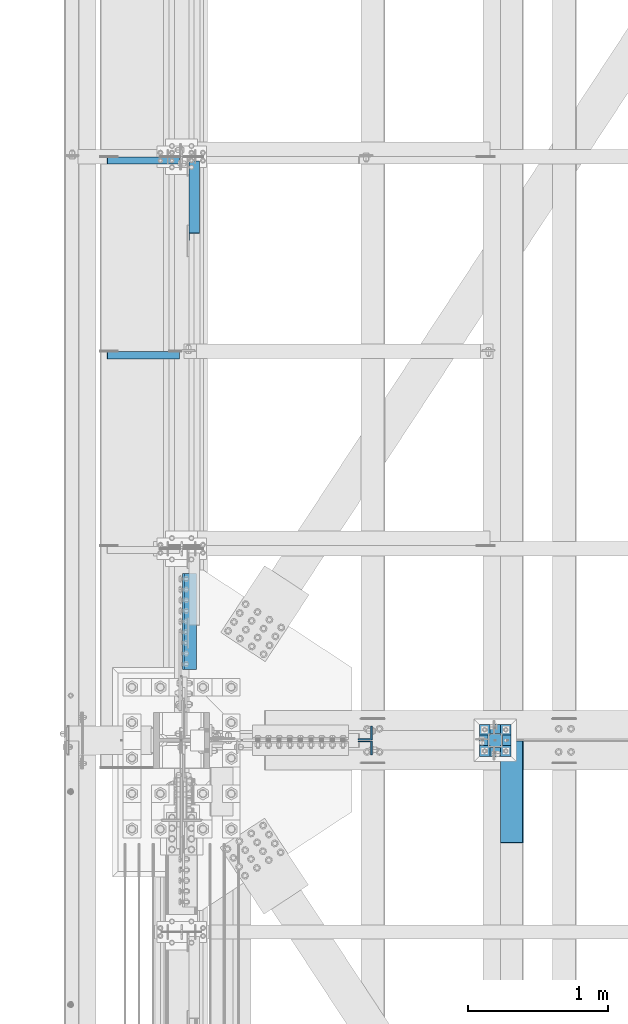
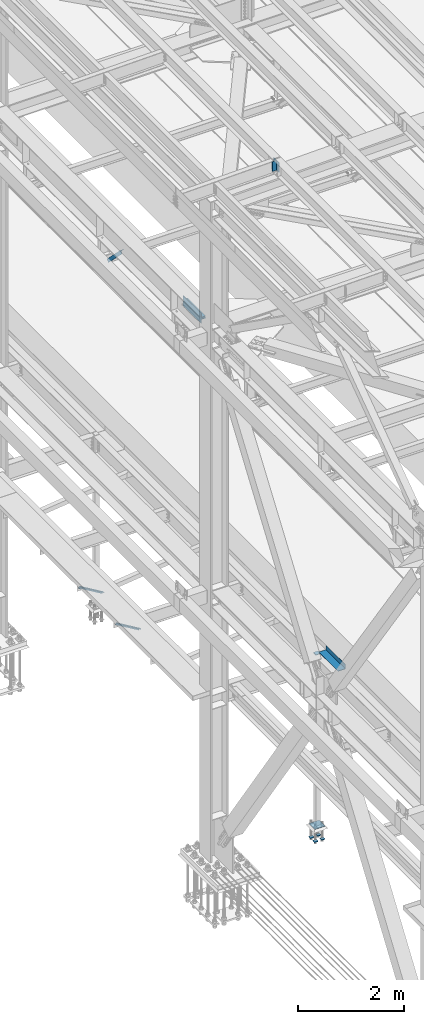
# One storey, part 2218 of 3843: 9 beams, 5 members, 8 elements without a shape of their own.
"""IFC2X3 building model written with IfcOpenShell, lengths in millimetres."""

from ifc_helpers import new_model, si_unit, frame, origin_with_axes, place, context, subcontext, project, spatial, faceted_brep, material, type_object, element, aggregate, save


model = new_model("IFC2X3")

# Units and contexts
model_context = context("Model", 3, precision=1e-05, world=origin_with_axes())
body_context = subcontext(model_context, "Body", "Model", "MODEL_VIEW")
ifc_project = project(units=[si_unit("LENGTHUNIT", "METRE", prefix="MILLI"), si_unit("AREAUNIT", "SQUARE_METRE"), si_unit("VOLUMEUNIT", "CUBIC_METRE"), si_unit("MASSUNIT", "GRAM", prefix="KILO"), si_unit("TIMEUNIT", "SECOND"), si_unit("PLANEANGLEUNIT", "RADIAN"), si_unit("SOLIDANGLEUNIT", "STERADIAN"), si_unit("THERMODYNAMICTEMPERATUREUNIT", "DEGREE_CELSIUS"), si_unit("LUMINOUSINTENSITYUNIT", "LUMEN")], contexts=[model_context])

# Site, building, storey
site_placement = place(None, origin_with_axes())
site = spatial("IfcSite", under=ifc_project, at=site_placement, CompositionType="ELEMENT")
building_placement = place(site_placement, origin_with_axes())
building = spatial("IfcBuilding", under=site, at=building_placement, Name="Undefined", CompositionType="ELEMENT")
storey_placement = place(building_placement, origin_with_axes())
storey = spatial("IfcBuildingStorey", under=building, at=storey_placement, Name="Undefined", CompositionType="ELEMENT", Elevation=0.0)

# Assembly, beam
assembly_1_placement = place(storey_placement, origin_with_axes())
assembly_1 = element("IfcElementAssembly", 1, at=assembly_1_placement, inside=storey, Name="BEAM", AssemblyPlace="NOTDEFINED", PredefinedType="RIGID_FRAME")
ifc_material_1 = material(Name="STEEL/A36")
beam_type_1 = type_object("IfcBeamType", PredefinedType="NOTDEFINED")
beam_1_placement = place(assembly_1_placement, frame((38858.825, 58547.0, 34039.175), z_axis=(0.0, -1.0, 0.0), x_axis=(1.0, 0.0, 0.0)))
beam_1 = element("IfcBeam", 2, at=beam_1_placement, type_object=beam_type_1, material=ifc_material_1, Name="BENT_PLATE", context=body_context, shape_type="Brep", body=[
    faceted_brep([(161.925005912773, 7.27595761418343e-12, 365.125000000029), (158.749999999993, 3.17500000000291, 361.950000000041), (0.0, 3.17500000000291, 361.950000000041), (0.0, 0.0, 365.125), (161.924999999988, 98.4249999999956, 365.125), (158.749999999993, 98.4249999999956, 361.950000000041), (165.099999999999, -3.17500000000291, -365.125), (0.0, -3.17500000000291, -365.125), (0.0, 3.17500000000291, -365.125), (158.749999999993, 3.17500000000291, -365.125), (158.749999999993, 98.4249999999956, -365.125), (165.099999999999, 98.4249999999956, -365.125), (165.099999999999, -3.17500000000291, 365.125), (165.099999999999, 98.4249999999956, 365.125), (0.0, -3.17500000000291, 365.125)], [[[0, 1, 2, 3]], [[4, 5, 1, 0]], [[6, 7, 8, 9, 10, 11]], [[12, 6, 11, 13]], [[14, 7, 6, 12]], [[8, 7, 14, 3, 2]], [[9, 8, 2, 1]], [[10, 9, 1, 5]], [[13, 11, 10, 5, 4]], [[14, 12, 13, 4, 0, 3]]]),
])
aggregate(assembly_1, [beam_1])

# Assembly, member
assembly_2_placement = place(storey_placement, origin_with_axes())
assembly_2 = element("IfcElementAssembly", 3, at=assembly_2_placement, inside=storey, Name="ANGLE", AssemblyPlace="NOTDEFINED", PredefinedType="RIGID_FRAME")
ifc_material_2 = material(Name="STEEL/A572-50")
member_type_1 = type_object("IfcMemberType", Name="L2X2X1/4", PredefinedType="NOTDEFINED")
member_1_placement = place(assembly_2_placement, frame((36032.7062298839, 63064.9257820001, 34001.5027629153), z_axis=(0.0, -1.0, 0.0), x_axis=(0.858158898344811, 0.0, -0.513384169206278)))
member_1 = element("IfcMember", 4, at=member_1_placement, type_object=member_type_1, material=ifc_material_2, Name="ANGLE", ObjectType="L2X2X1/4", context=body_context, shape_type="Brep", body=[
    faceted_brep([(0.0, 25.4000000000015, -25.4000000000015), (0.0, 25.4000000000015, 25.4000000000015), (598.473132324763, 25.3999999988228, 25.3999999999942), (598.473132324763, 25.3999999988228, -25.3999999999942), (0.0, 19.0500000000029, 25.4000000000015), (598.473132324745, 19.0499999988242, 25.3999999999942), (0.0, 19.0500000000029, -19.0499999999993), (598.473132324745, 19.0499999988242, -19.0500000000029), (0.0, -25.4000000000015, -19.0499999999993), (598.473132324661, -25.4000000011511, -19.0500000000029), (0.0, -25.4000000000015, -25.4000000000015), (598.473132324661, -25.4000000011511, -25.3999999999942)], [[[0, 1, 2, 3]], [[1, 4, 5, 2]], [[4, 6, 7, 5]], [[6, 8, 9, 7]], [[8, 10, 11, 9]], [[10, 0, 3, 11]], [[5, 7, 9, 11, 3, 2]], [[10, 8, 6, 4, 1, 0]]]),
])
aggregate(assembly_2, [member_1])

assembly_3_placement = place(storey_placement, origin_with_axes())
assembly_3 = element("IfcElementAssembly", 5, at=assembly_3_placement, inside=storey, Name="ANGLE", AssemblyPlace="NOTDEFINED", PredefinedType="RIGID_FRAME")
member_2_placement = place(assembly_3_placement, frame((36032.7062481198, 61672.1921880001, 34001.5027629153), z_axis=(0.0, -1.0, 0.0), x_axis=(0.858158898344811, 0.0, -0.513384169206278)))
member_2 = element("IfcMember", 6, at=member_2_placement, type_object=member_type_1, material=ifc_material_2, Name="ANGLE", ObjectType="L2X2X1/4", context=body_context, shape_type="Brep", body=[
    faceted_brep([(0.0, 25.4000000000015, -25.4000000000015), (0.0, 25.4000000000015, 25.4000000000015), (598.473132324763, 25.3999999988228, 25.3999999999942), (598.473132324763, 25.3999999988228, -25.3999999999942), (0.0, 19.0500000000029, 25.4000000000015), (598.473132324745, 19.0499999988242, 25.3999999999942), (0.0, 19.0500000000029, -19.0499999999993), (598.473132324745, 19.0499999988242, -19.0500000000029), (0.0, -25.4000000000015, -19.0499999999993), (598.473132324661, -25.4000000011511, -19.0500000000029), (0.0, -25.4000000000015, -25.4000000000015), (598.473132324661, -25.4000000011511, -25.3999999999942)], [[[0, 1, 2, 3]], [[1, 4, 5, 2]], [[4, 6, 7, 5]], [[6, 8, 9, 7]], [[8, 10, 11, 9]], [[10, 0, 3, 11]], [[5, 7, 9, 11, 3, 2]], [[10, 8, 6, 4, 1, 0]]]),
])
aggregate(assembly_3, [member_2])

# Assembly, beams
assembly_4_placement = place(storey_placement, origin_with_axes())
assembly_4 = element("IfcElementAssembly", 7, at=assembly_4_placement, inside=storey, Name="PLATE", AssemblyPlace="NOTDEFINED", PredefinedType="RIGID_FRAME")
beam_type_2 = type_object("IfcBeamType", Name="L4X4X1/2", PredefinedType="NOTDEFINED")
beam_2_placement = place(assembly_4_placement, frame((36633.1499999978, 60109.1, 42297.3500007635), z_axis=(1.0, 0.0, 0.0), x_axis=(0.0, -1.0, 0.0)))
beam_2 = element("IfcBeam", 8, at=beam_2_placement, type_object=beam_type_2, material=ifc_material_2, Name="ANGLE", ObjectType="L4X4X1/2", context=body_context, shape_type="Brep", body=[
    faceted_brep([(0.0, 50.8000000000029, -50.8000000000029), (0.0, 50.8000000000029, 50.8000000000029), (685.800000000003, 50.8000000000029, 50.8000000000029), (685.800000000003, 50.8000000000029, -50.8000000000029), (0.0, 38.0999999999985, 50.8000000000029), (685.800000000003, 38.0999999999985, 50.8000000000029), (0.0, 38.0999999999985, -38.0999999999985), (685.800000000003, 38.0999999999985, -38.1000000000058), (0.0, -50.8000000000029, -38.1000000000058), (685.800000000003, -50.8000000000029, -38.1000000000058), (0.0, -50.8000000000029, -50.8000000000029), (685.800000000003, -50.8000000000029, -50.8000000000029)], [[[0, 1, 2, 3]], [[1, 4, 5, 2]], [[4, 6, 7, 5]], [[6, 8, 9, 7]], [[8, 10, 11, 9]], [[10, 0, 3, 11]], [[5, 7, 9, 11, 3, 2]], [[10, 8, 6, 4, 1, 0]]]),
])
beam_3_placement = place(assembly_4_placement, frame((36633.1499999978, 59423.3, 42167.1750000005), z_axis=(1.0, 0.0, 0.0), x_axis=(0.0, 1.0, 0.0)))
beam_3 = element("IfcBeam", 9, at=beam_3_placement, type_object=beam_type_2, material=ifc_material_2, Name="ANGLE", ObjectType="L4X4X1/2", context=body_context, shape_type="Brep", body=[
    faceted_brep([(0.0, 50.8000000000029, -50.8000000000029), (0.0, 50.8000000000029, 50.8000000000029), (685.800000000003, 50.8000000000029, 50.8000000000029), (685.800000000003, 50.8000000000029, -50.8000000000029), (0.0, 38.0999999999985, 50.8000000000029), (685.800000000003, 38.0999999999985, 50.8000000000029), (0.0, 38.0999999999985, -38.0999999999985), (685.800000000003, 38.0999999999985, -38.1000000000058), (0.0, -50.8000000000029, -38.1000000000058), (685.800000000003, -50.8000000000029, -38.1000000000058), (0.0, -50.8000000000029, -50.8000000000029), (685.800000000003, -50.8000000000029, -50.8000000000029)], [[[0, 1, 2, 3]], [[1, 4, 5, 2]], [[4, 6, 7, 5]], [[6, 8, 9, 7]], [[8, 10, 11, 9]], [[10, 0, 3, 11]], [[5, 7, 9, 11, 3, 2]], [[10, 8, 6, 4, 1, 0]]]),
])
aggregate(assembly_4, [beam_2, beam_3])

# Assembly, members
assembly_5_placement = place(storey_placement, origin_with_axes())
assembly_5 = element("IfcElementAssembly", 10, at=assembly_5_placement, inside=storey, Name="BEAM", AssemblyPlace="NOTDEFINED", PredefinedType="RIGID_FRAME")
member_type_2 = type_object("IfcMemberType", Name="L4X4X3/8", PredefinedType="NOTDEFINED")
member_3_placement = place(assembly_5_placement, frame((37892.6968641658, 58969.2749999523, 45499.0421537386), z_axis=(0.0, 1.0, 0.0), x_axis=(-0.0211520980073474, 0.0, 0.999776269347241)))
member_3 = element("IfcMember", 11, at=member_3_placement, type_object=member_type_2, material=ifc_material_2, Name="ANGLE", ObjectType="L4X4X3/8", context=body_context, shape_type="Brep", body=[
    faceted_brep([(0.0, 50.8000000000029, -50.8000000000029), (0.0, 50.8000000000029, 50.8000000000029), (228.599999994367, 50.7999999996973, 50.8000000000029), (228.599999994367, 50.7999999996973, -50.8000000000029), (0.0, 41.2750000000015, 50.8000000000029), (228.599999994345, 41.2749999997031, 50.8000000000029), (0.0, 41.2749999999942, -41.2750000000015), (228.599999994345, 41.2749999997031, -41.2750000000015), (0.0, -50.8000000000029, -41.2750000000015), (228.599999994258, -50.8000000001412, -41.2750000000015), (0.0, -50.8000000000029, -50.8000000000029), (228.599999994258, -50.8000000001412, -50.8000000000029)], [[[0, 1, 2, 3]], [[1, 4, 5, 2]], [[4, 6, 7, 5]], [[6, 8, 9, 7]], [[8, 10, 11, 9]], [[10, 0, 3, 11]], [[5, 7, 9, 11, 3, 2]], [[10, 8, 6, 4, 1, 0]]]),
])
member_4_placement = place(assembly_5_placement, frame((37887.8614945605, 58861.3250000477, 45727.591008906), z_axis=(0.0, -1.0, 0.0), x_axis=(0.0211520550054438, 0.0, -0.999776270257025)))
member_4 = element("IfcMember", 12, at=member_4_placement, type_object=member_type_2, material=ifc_material_2, Name="ANGLE", ObjectType="L4X4X3/8", context=body_context, shape_type="Brep", body=[
    faceted_brep([(0.0, 50.8000000000029, -50.8000000000029), (0.0, 50.8000000000029, 50.8000000000029), (228.599999994367, 50.7999999996973, 50.8000000000029), (228.599999994367, 50.7999999996973, -50.8000000000029), (0.0, 41.2750000000015, 50.8000000000029), (228.599999994345, 41.2749999997031, 50.8000000000029), (0.0, 41.2749999999942, -41.2750000000015), (228.599999994345, 41.2749999997031, -41.2750000000015), (0.0, -50.8000000000029, -41.2750000000015), (228.599999994258, -50.8000000001412, -41.2750000000015), (0.0, -50.8000000000029, -50.8000000000029), (228.599999994258, -50.8000000001412, -50.8000000000029)], [[[0, 1, 2, 3]], [[1, 4, 5, 2]], [[4, 6, 7, 5]], [[6, 8, 9, 7]], [[8, 10, 11, 9]], [[10, 0, 3, 11]], [[5, 7, 9, 11, 3, 2]], [[10, 8, 6, 4, 1, 0]]]),
])
aggregate(assembly_5, [member_3, member_4])

# Assembly, member
assembly_6_placement = place(storey_placement, origin_with_axes())
assembly_6 = element("IfcElementAssembly", 13, at=assembly_6_placement, inside=storey, Name="ANGLE", AssemblyPlace="NOTDEFINED", PredefinedType="RIGID_FRAME")
member_type_3 = type_object("IfcMemberType", Name="L3X3X1/4", PredefinedType="NOTDEFINED")
member_5_placement = place(assembly_6_placement, frame((36664.9, 63093.6, 41300.4), z_axis=(0.0, -0.707106781186548, -0.707106781186548), x_axis=(0.0, -0.707106781186682, 0.707106781186413)))
member_5 = element("IfcMember", 14, at=member_5_placement, type_object=member_type_3, material=ifc_material_2, Name="ANGLE", ObjectType="L3X3X1/4", context=body_context, shape_type="Brep", body=[
    faceted_brep([(83.0012806675732, 38.0999999999985, -38.0999999999058), (83.0012806675732, -38.0999999999985, -38.0999999999058), (83.0012806675804, -38.0999999999985, -31.7499999999254), (83.0012806675804, 31.75, -31.7499999999254), (83.0012806675804, 31.75, 38.0999999999058), (83.0012806675804, 38.0999999999985, 38.0999999999058), (810.534203444928, 31.75, 38.0999999999112), (810.534203444928, 38.0999999999985, 38.0999999999112), (810.534203444538, 38.0999999999985, -38.099999999904), (810.534203444538, -38.0999999999985, -38.099999999904), (810.534203444575, -38.0999999999985, -31.7499999999272), (810.534203444575, 31.75, -31.7499999999272)], [[[0, 1, 2, 3, 4, 5]], [[5, 4, 6, 7]], [[0, 5, 7, 8]], [[1, 0, 8, 9]], [[2, 1, 9, 10]], [[3, 2, 10, 11]], [[4, 3, 11, 6]], [[10, 9, 8, 7, 6, 11]]]),
])
aggregate(assembly_6, [member_5])

# Assembly, beam
assembly_7_placement = place(storey_placement, origin_with_axes())
assembly_7 = element("IfcElementAssembly", 15, at=assembly_7_placement, inside=storey, Name="COLUMN", AssemblyPlace="NOTDEFINED", PredefinedType="RIGID_FRAME")
beam_type_3 = type_object("IfcBeamType", PredefinedType="NOTDEFINED")
beam_4_placement = place(assembly_7_placement, frame((38871.525, 58915.3, 34029.65), z_axis=(0.0, 1.0, 0.0), x_axis=(-1.0, 0.0, 0.0)))
beam_4 = element("IfcBeam", 16, at=beam_4_placement, type_object=beam_type_3, material=ifc_material_2, Name="PLATE", context=body_context, shape_type="Brep", body=[
    faceted_brep([(0.0, 6.34999999999854, -50.8000000000029), (0.0, 6.35000000000582, 50.7999992361001), (101.600000000006, 6.34999999999854, 50.8000000000029), (101.600000000006, 6.34999999999854, -50.8000000000029), (0.0, -6.35000000000582, 50.7999992361001), (101.600000000006, -6.34999999999854, 50.8000000000029), (0.0, -6.34999999999854, -50.8000000000029), (101.600000000006, -6.34999999999854, -50.8000000000029)], [[[0, 1, 2, 3]], [[1, 4, 5, 2]], [[4, 6, 7, 5]], [[6, 0, 3, 7]], [[5, 7, 3, 2]], [[6, 4, 1, 0]]]),
])
aggregate(assembly_7, [beam_4])

# Assembly, beams
assembly_8_placement = place(storey_placement, origin_with_axes())
assembly_8 = element("IfcElementAssembly", 17, at=assembly_8_placement, inside=storey, Name="TEMPLATE", AssemblyPlace="NOTDEFINED", PredefinedType="RIGID_FRAME")
beam_type_4 = type_object("IfcBeamType", PredefinedType="NOTDEFINED")
beam_5_placement = place(assembly_8_placement, frame((38935.025, 58839.1, 29762.45), z_axis=(0.0, 1.0, 0.0), x_axis=(-1.0, 0.0, 0.0)))
beam_5 = element("IfcBeam", 18, at=beam_5_placement, type_object=beam_type_4, material=ifc_material_2, context=body_context, shape_type="Brep", body=[
    faceted_brep([(0.0, 6.34999999999854, -38.1000000000058), (0.0, 6.34999999999854, 38.0999984741211), (76.1999999999971, 6.34999999999854, 38.1000000000058), (76.1999999999971, 6.34999999999854, -38.1000000000058), (0.0, -6.34999999999854, 38.0999984741211), (76.1999999999971, -6.34999999999854, 38.1000000000058), (0.0, -6.34999999999854, -38.1000000000058), (76.1999999999971, -6.34999999999854, -38.1000000000058)], [[[0, 1, 2, 3]], [[1, 4, 5, 2]], [[4, 6, 7, 5]], [[6, 0, 3, 7]], [[5, 7, 3, 2]], [[6, 4, 1, 0]]]),
])
beam_6_placement = place(assembly_8_placement, frame((38935.025, 58991.5, 29762.45), z_axis=(0.0, 1.0, 0.0), x_axis=(-1.0, 0.0, 0.0)))
beam_6 = element("IfcBeam", 19, at=beam_6_placement, type_object=beam_type_4, material=ifc_material_2, context=body_context, shape_type="Brep", body=[
    faceted_brep([(0.0, 6.34999999999854, -38.1000000000058), (0.0, 6.34999999999854, 38.0999984741211), (76.1999999999971, 6.34999999999854, 38.1000000000058), (76.1999999999971, 6.34999999999854, -38.1000000000058), (0.0, -6.34999999999854, 38.0999984741211), (76.1999999999971, -6.34999999999854, 38.1000000000058), (0.0, -6.34999999999854, -38.1000000000058), (76.1999999999971, -6.34999999999854, -38.1000000000058)], [[[0, 1, 2, 3]], [[1, 4, 5, 2]], [[4, 6, 7, 5]], [[6, 0, 3, 7]], [[5, 7, 3, 2]], [[6, 4, 1, 0]]]),
])
beam_7_placement = place(assembly_8_placement, frame((38782.625, 58839.1, 29762.45), z_axis=(0.0, 1.0, 0.0), x_axis=(-1.0, 0.0, 0.0)))
beam_7 = element("IfcBeam", 20, at=beam_7_placement, type_object=beam_type_4, material=ifc_material_2, context=body_context, shape_type="Brep", body=[
    faceted_brep([(0.0, 6.34999999999854, -38.1000000000058), (0.0, 6.34999999999854, 38.0999984741211), (76.1999999999971, 6.34999999999854, 38.1000000000058), (76.1999999999971, 6.34999999999854, -38.1000000000058), (0.0, -6.34999999999854, 38.0999984741211), (76.1999999999971, -6.34999999999854, 38.1000000000058), (0.0, -6.34999999999854, -38.1000000000058), (76.1999999999971, -6.34999999999854, -38.1000000000058)], [[[0, 1, 2, 3]], [[1, 4, 5, 2]], [[4, 6, 7, 5]], [[6, 0, 3, 7]], [[5, 7, 3, 2]], [[6, 4, 1, 0]]]),
])
beam_8_placement = place(assembly_8_placement, frame((38782.625, 58991.5, 29762.45), z_axis=(0.0, 1.0, 0.0), x_axis=(-1.0, 0.0, 0.0)))
beam_8 = element("IfcBeam", 21, at=beam_8_placement, type_object=beam_type_4, material=ifc_material_2, context=body_context, shape_type="Brep", body=[
    faceted_brep([(0.0, 6.34999999999854, -38.1000000000058), (0.0, 6.34999999999854, 38.0999984741211), (76.1999999999971, 6.34999999999854, 38.1000000000058), (76.1999999999971, 6.34999999999854, -38.1000000000058), (0.0, -6.34999999999854, 38.0999984741211), (76.1999999999971, -6.34999999999854, 38.1000000000058), (0.0, -6.34999999999854, -38.1000000000058), (76.1999999999971, -6.34999999999854, -38.1000000000058)], [[[0, 1, 2, 3]], [[1, 4, 5, 2]], [[4, 6, 7, 5]], [[6, 0, 3, 7]], [[5, 7, 3, 2]], [[6, 4, 1, 0]]]),
])
beam_type_5 = type_object("IfcBeamType", PredefinedType="NOTDEFINED")
beam_9_placement = place(assembly_8_placement, frame((38935.025, 58915.3, 30062.4875), z_axis=(0.0, -1.0, 0.0), x_axis=(-1.0, 0.0, 0.0)))
beam_9 = element("IfcBeam", 22, at=beam_9_placement, type_object=beam_type_5, material=ifc_material_2, Name="TEMPLATE", context=body_context, shape_type="Brep", body=[
    faceted_brep([(0.0, 1.58750000000146, -114.300000000003), (0.0, 1.58750000000146, 114.300000000003), (228.600000000006, 1.58750000000146, 114.300000000003), (228.600000000006, 1.58750000000146, -114.300000000003), (0.0, -1.58750000000146, 114.300000000003), (228.600000000006, -1.58750000000146, 114.300000000003), (0.0, -1.58750000000146, -114.300000000003), (228.600000000006, -1.58750000000146, -114.300000000003)], [[[0, 1, 2, 3]], [[1, 4, 5, 2]], [[4, 6, 7, 5]], [[6, 0, 3, 7]], [[5, 7, 3, 2]], [[6, 4, 1, 0]]]),
])
aggregate(assembly_8, [beam_5, beam_6, beam_7, beam_8, beam_9])

save(model, "model.ifc")
